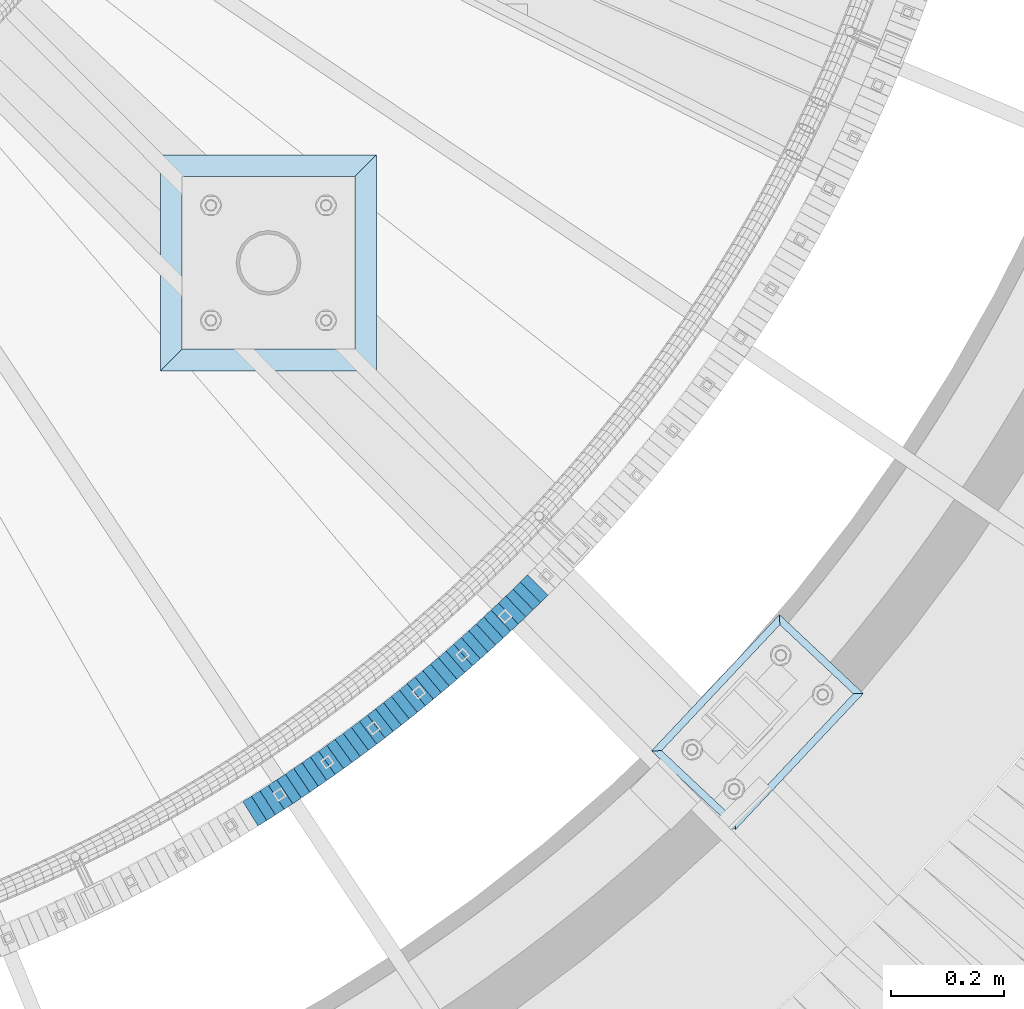
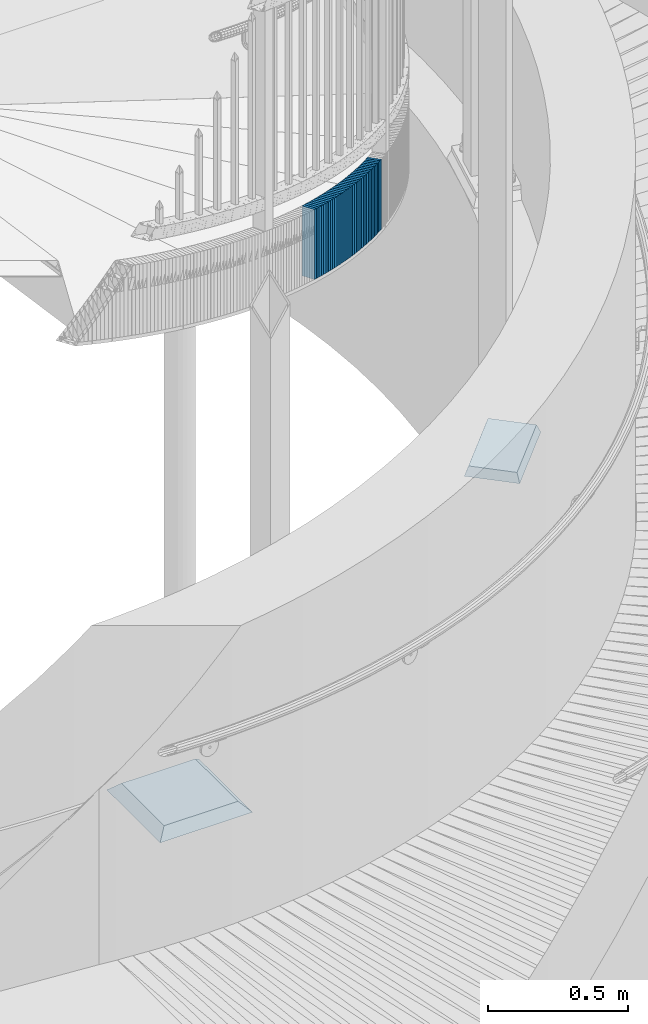
# One storey, part 904 of 975: 38 plates.
"""IFC2X3 building model written with IfcOpenShell, lengths in millimetres."""

import ifcopenshell
import ifcopenshell.guid

model = None  # the IFC model being written
_history = None  # IfcOwnerHistory: only IFC2X3 demands one
_inside = {}  # id of a spatial element -> (the spatial element, [elements in it])
_under = {}  # id of a project, library or spatial element -> (it, [spatial elements below it])
_declared = {}  # id of a project -> (the project, [libraries it declares])
_typed = {}  # id of a type object -> (the type object, [elements of that type])
_made_of = {}  # id of a material, layer set ... -> (it, [elements and type objects made of it])


def new_model(schema):
    """Start an empty IFC model of exactly this schema.

    Asked for "IFC4X3", IfcOpenShell would pick the latest addendum, in which some entities
    have other attributes; the version numbers below select the first issue.
    IFC2X3 requires an IfcOwnerHistory on every rooted entity: one is made here for all.
    """
    global model, _history
    if schema == "IFC4X3":
        model = ifcopenshell.file(schema_version=(4, 3, 0, 0))
    else:
        model = ifcopenshell.file(schema=schema)
    _inside.clear()
    _under.clear()
    _declared.clear()
    _typed.clear()
    _made_of.clear()
    _history = None
    if model.schema == "IFC2X3":
        org = make("IfcOrganization", Name="unknown")
        user = make(
            "IfcPersonAndOrganization",
            ThePerson=make("IfcPerson", FamilyName="unknown"),
            TheOrganization=org,
        )
        app = make(
            "IfcApplication",
            ApplicationDeveloper=org,
            Version="unknown",
            ApplicationFullName="unknown",
            ApplicationIdentifier="unknown",
        )
        _history = make(
            "IfcOwnerHistory",
            OwningUser=user,
            OwningApplication=app,
            ChangeAction="ADDED",
            CreationDate=0,
        )
    return model


def make(cls, **values):
    """One entity of the class cls with the attributes given. An attribute that is None is left unset."""
    return model.create_entity(
        cls, **{name: value for name, value in values.items() if value is not None}
    )


def rooted(cls, **values):
    """An entity with a GlobalId (a new one), such as an element, a storey or a relation."""
    return make(cls, GlobalId=ifcopenshell.guid.new(), OwnerHistory=_history, **values)


def si_unit(unit_type, name, prefix=None):
    """IfcSIUnit, for example si_unit("LENGTHUNIT", "METRE", prefix="MILLI")."""
    return make("IfcSIUnit", UnitType=unit_type, Prefix=prefix, Name=name)


def assignment(units):
    """IfcUnitAssignment: the units of a project."""
    return None if units is None else make("IfcUnitAssignment", Units=units)


def point(xyz):
    """IfcCartesianPoint."""
    return None if xyz is None else make("IfcCartesianPoint", Coordinates=xyz)


def direction(xyz):
    """IfcDirection."""
    return None if xyz is None else make("IfcDirection", DirectionRatios=xyz)


def frame(location, z_axis=None, x_axis=None):
    """IfcAxis2Placement3D, a coordinate frame: its origin and axes. An axis left out is left unset."""
    return make(
        "IfcAxis2Placement3D",
        Location=point(location),
        Axis=direction(z_axis),
        RefDirection=direction(x_axis),
    )


def origin_with_axes():
    """The frame at (0, 0, 0) with the z axis (0, 0, 1) and the x axis (1, 0, 0) written out."""
    return frame((0.0, 0.0, 0.0), z_axis=(0.0, 0.0, 1.0), x_axis=(1.0, 0.0, 0.0))


def place(relative_to, where):
    """IfcLocalPlacement: puts the frame where relative to a parent placement (None: the world)."""
    return make(
        "IfcLocalPlacement", PlacementRelTo=relative_to, RelativePlacement=where
    )


def context(
    kind, dimensions, precision=None, world=None, true_north=None, identifier=None
):
    """IfcGeometricRepresentationContext, for example the 3D "Model" context."""
    return make(
        "IfcGeometricRepresentationContext",
        ContextIdentifier=identifier,
        ContextType=kind,
        CoordinateSpaceDimension=dimensions,
        Precision=precision,
        WorldCoordinateSystem=world,
        TrueNorth=true_north,
    )


def subcontext(parent, identifier, kind, view, scale=None):
    """IfcGeometricRepresentationSubContext, for example "Body" below "Model"."""
    return make(
        "IfcGeometricRepresentationSubContext",
        ContextIdentifier=identifier,
        ContextType=kind,
        ParentContext=parent,
        TargetScale=scale,
        TargetView=view,
    )


def project(units=None, contexts=None):
    """IfcProject with its units and contexts."""
    return rooted(
        "IfcProject",
        Name="project",
        RepresentationContexts=contexts,
        UnitsInContext=assignment(units),
    )


def spatial(cls, under=None, at=None, **own):
    """A site, building, storey or space (cls), placed at a placement, below another one or the project."""
    s = rooted(cls, ObjectPlacement=at, **own)
    if under is not None:
        _under.setdefault(under.id(), (under, []))[1].append(s)
    return s


def faces_of(points, faces, orient=None, outer=None):
    """IfcFace entities. A face is a list of loops; a loop is a list of indices into points, from 0.

    orient and outer hold one flag for each loop. By default every Orientation is true, the
    first loop of a face is its IfcFaceOuterBound and the others are IfcFaceBound.
    """
    made = []
    for i, loops in enumerate(faces):
        bounds = []
        for j, loop in enumerate(loops):
            is_outer = j == 0 if outer is None else outer[i][j]
            bounds.append(
                make(
                    "IfcFaceOuterBound" if is_outer else "IfcFaceBound",
                    Bound=make("IfcPolyLoop", Polygon=[points[k] for k in loop]),
                    Orientation=True if orient is None else orient[i][j],
                )
            )
        made.append(make("IfcFace", Bounds=bounds))
    return made


def faceted_brep(points, faces, orient=None, outer=None, voids=None):
    """IfcFacetedBrep: a solid bounded by flat faces; with voids (closed shells), ...WithVoids."""
    shared = [point(p) for p in points]
    hull = make("IfcClosedShell", CfsFaces=faces_of(shared, faces, orient, outer))
    if voids is None:
        return make("IfcFacetedBrep", Outer=hull)
    return make(
        "IfcFacetedBrepWithVoids",
        Outer=hull,
        Voids=[
            make(cls, CfsFaces=faces_of(shared, fs, o, b)) for cls, fs, o, b in voids
        ],
    )


def shape(context_of_items, identifier, shape_type, items):
    """IfcShapeRepresentation: the items that make up one representation, for example the "Body"."""
    return make(
        "IfcShapeRepresentation",
        ContextOfItems=context_of_items,
        RepresentationIdentifier=identifier,
        RepresentationType=shape_type,
        Items=items,
    )


def material(Name=None, Category=None):
    """IfcMaterial."""
    return make("IfcMaterial", Name=Name, Category=Category)


def made_of(thing, what):
    """Note that an element or type object is made of a material, layer set ...; save() writes the relation."""
    if what is not None:
        _made_of.setdefault(what.id(), (what, []))[1].append(thing)
    return thing


def type_object(cls, material=None, **own):
    """A type object (cls), such as IfcWallType, which elements share."""
    return made_of(rooted(cls, **own), material)


def element(
    cls,
    number,
    at=None,
    inside=None,
    cuts=None,
    type_object=None,
    material=None,
    context=None,
    identifier="Body",
    shape_type=None,
    held_by="IfcProductDefinitionShape",
    body=None,
    shapes=None,
    **own,
):
    """One element of the class cls, such as IfcWall. Its Tag is "e" and its number.

    at: its placement. inside: the storey or other place that contains it. cuts: it is an
    opening in that element (IfcRelVoidsElement). A single representation is given by context,
    identifier, shape_type and body (its items); several are given by shapes. held_by: the class
    of the entity that holds the representations. save() writes the other relations.
    """
    e = rooted(cls, Tag="e%d" % number, ObjectPlacement=at, **own)
    if body is not None:
        shapes = [shape(context, identifier, shape_type, body)]
    if shapes is not None:
        e.Representation = make(held_by, Representations=shapes)
    if inside is not None:
        _inside.setdefault(inside.id(), (inside, []))[1].append(e)
    if cuts is not None:
        rooted(
            "IfcRelVoidsElement", RelatingBuildingElement=cuts, RelatedOpeningElement=e
        )
    if type_object is not None:
        _typed.setdefault(type_object.id(), (type_object, []))[1].append(e)
    return made_of(e, material)


def aggregate(whole, parts):
    """IfcRelAggregates: a whole, such as a stair, and the parts it consists of."""
    return rooted("IfcRelAggregates", RelatingObject=whole, RelatedObjects=parts)


def save(model, path):
    """Write the relations noted so far, then the file.

    IfcRelAggregates (storeys below a building ...), IfcRelContainedInSpatialStructure (elements
    in a storey), IfcRelDefinesByType, IfcRelAssociatesMaterial and IfcRelDeclares: one each for
    every whole, place, type object, material and project.
    """
    for whole, parts in _under.values():
        aggregate(whole, parts)
    for where, things in _inside.values():
        rooted(
            "IfcRelContainedInSpatialStructure",
            RelatedElements=things,
            RelatingStructure=where,
        )
    for kind, things in _typed.values():
        rooted("IfcRelDefinesByType", RelatedObjects=things, RelatingType=kind)
    for what, things in _made_of.values():
        rooted("IfcRelAssociatesMaterial", RelatedObjects=things, RelatingMaterial=what)
    for by, libraries in _declared.values():
        rooted("IfcRelDeclares", RelatingContext=by, RelatedDefinitions=libraries)
    model.write(path)


model = new_model("IFC2X3")

# Units and contexts
model_context = context("Model", 3, precision=1e-05, world=origin_with_axes())
body_context = subcontext(model_context, "Body", "Model", "MODEL_VIEW")
ifc_project = project(units=[si_unit("LENGTHUNIT", "METRE", prefix="MILLI"), si_unit("AREAUNIT", "SQUARE_METRE"), si_unit("VOLUMEUNIT", "CUBIC_METRE"), si_unit("MASSUNIT", "GRAM", prefix="KILO"), si_unit("TIMEUNIT", "SECOND"), si_unit("PLANEANGLEUNIT", "RADIAN"), si_unit("SOLIDANGLEUNIT", "STERADIAN"), si_unit("THERMODYNAMICTEMPERATUREUNIT", "DEGREE_CELSIUS"), si_unit("LUMINOUSINTENSITYUNIT", "LUMEN")], contexts=[model_context])

# Site, building, storey
site_placement = place(None, origin_with_axes())
site = spatial("IfcSite", under=ifc_project, at=site_placement, CompositionType="ELEMENT")
building_placement = place(site_placement, origin_with_axes())
building = spatial("IfcBuilding", under=site, at=building_placement, Name="Undefined", CompositionType="ELEMENT")
storey_placement = place(building_placement, origin_with_axes())
storey = spatial("IfcBuildingStorey", under=building, at=storey_placement, Name="Undefined", CompositionType="ELEMENT", Elevation=0.0)

# Plates
ifc_material_1 = material(Name="STEEL/A36")
plate_type_1 = type_object("IfcPlateType", PredefinedType="NOTDEFINED")
plate_1_placement = place(storey_placement, frame((36272.917348315, 979.903172533605, 2546.48750006771), z_axis=(-0.846420002588978, -0.532515895741408, 0.0), x_axis=(0.0, 0.0, 1.0)))
element("IfcPlate", 1, at=plate_1_placement, inside=storey, type_object=plate_type_1, material=ifc_material_1, Name="WALL", context=body_context, shape_type="Brep", body=[
    faceted_brep([(0.0, -25.3999999999724, -1.81898940354586e-11), (5.69999980926514, -25.3999999999651, 17.8440475463649), (5.69999980926514, 25.3999999999942, 17.8440475463904), (0.0, 25.3999999999869, 1.45519152283669e-11), (310.5, -25.3999999999651, 17.8440475463649), (310.5, 25.3999999999942, 17.8440475463904), (304.799987792969, -25.3999999999724, -1.81898940354586e-11), (304.799987792969, 25.3999999999869, 1.45519152283669e-11)], [[[0, 1, 2, 3]], [[1, 4, 5, 2]], [[4, 6, 7, 5]], [[6, 0, 3, 7]], [[5, 7, 3, 2]], [[6, 4, 1, 0]]]),
])
plate_2_placement = place(storey_placement, frame((36288.1188956409, 989.567395668225, 2540.68750006771), z_axis=(-0.843891532718926, -0.536513821821304, 0.0), x_axis=(0.0, 0.0, 1.0)))
element("IfcPlate", 2, at=plate_2_placement, inside=storey, type_object=plate_type_1, material=ifc_material_1, Name="WALL", context=body_context, shape_type="Brep", body=[
    faceted_brep([(0.0, -25.3999999999724, -1.81898940354586e-11), (5.80000019073486, -25.4000000000451, 17.8891029358201), (5.80000019073486, 25.4000000000087, 17.8891029357856), (0.0, 25.3999999999869, 1.45519152283669e-11), (310.600006103516, -25.4000000000451, 17.8891029358201), (310.600006103516, 25.4000000000087, 17.8891029357856), (304.799987792969, -25.3999999999724, -1.81898940354586e-11), (304.799987792969, 25.3999999999869, 1.45519152283669e-11)], [[[0, 1, 2, 3]], [[1, 4, 5, 2]], [[4, 6, 7, 5]], [[6, 0, 3, 7]], [[5, 7, 3, 2]], [[6, 4, 1, 0]]]),
])
plate_3_placement = place(storey_placement, frame((36303.2841307244, 999.373344502733, 2534.98750006771), z_axis=(-0.83972031877, -0.543019139851267, 0.0), x_axis=(0.0, 0.0, 1.0)))
element("IfcPlate", 3, at=plate_3_placement, inside=storey, type_object=plate_type_1, material=ifc_material_1, Name="WALL", context=body_context, shape_type="Brep", body=[
    faceted_brep([(0.0, -25.3999999999724, -1.81898940354586e-11), (5.69999980926514, -25.4000000000378, 17.8639297485788), (5.69999980926514, 25.3999999999833, 17.8639297485533), (0.0, 25.3999999999869, 1.45519152283669e-11), (310.5, -25.4000000000378, 17.8639297485788), (310.5, 25.3999999999833, 17.8639297485533), (304.799987792969, -25.3999999999724, -1.81898940354586e-11), (304.799987792969, 25.3999999999869, 1.45519152283669e-11)], [[[0, 1, 2, 3]], [[1, 4, 5, 2]], [[4, 6, 7, 5]], [[6, 0, 3, 7]], [[5, 7, 3, 2]], [[6, 4, 1, 0]]]),
])
plate_4_placement = place(storey_placement, frame((36318.3490877869, 1009.28092593627, 2529.28750006771), z_axis=(-0.835484829267466, -0.549513512175918, 0.0), x_axis=(0.0, 0.0, 1.0)))
element("IfcPlate", 4, at=plate_4_placement, inside=storey, type_object=plate_type_1, material=ifc_material_1, Name="WALL", context=body_context, shape_type="Brep", body=[
    faceted_brep([(0.0, -25.3999999999724, -1.81898940354586e-11), (5.69999980926514, -25.3999999999724, 17.833955764745), (5.69999980926514, 25.3999999999905, 17.8339557647923), (0.0, 25.3999999999869, 1.45519152283669e-11), (310.5, -25.3999999999724, 17.833955764745), (310.5, 25.3999999999905, 17.8339557647923), (304.799987792969, -25.3999999999724, -1.81898940354586e-11), (304.799987792969, 25.3999999999869, 1.45519152283669e-11)], [[[0, 1, 2, 3]], [[1, 4, 5, 2]], [[4, 6, 7, 5]], [[6, 0, 3, 7]], [[5, 7, 3, 2]], [[6, 4, 1, 0]]]),
])
plate_5_placement = place(storey_placement, frame((36333.3480466602, 1019.24634454331, 2523.48750006771), z_axis=(-0.832909293569711, -0.553409530714104, 0.0), x_axis=(0.0, 0.0, 1.0)))
element("IfcPlate", 5, at=plate_5_placement, inside=storey, type_object=plate_type_1, material=ifc_material_1, Name="WALL", context=body_context, shape_type="Brep", body=[
    faceted_brep([(0.0, -25.3999999999724, -1.81898940354586e-11), (5.80000019073486, -25.4000000000451, 17.8891029358201), (5.80000019073486, 25.4000000000087, 17.8891029357856), (0.0, 25.3999999999869, 1.45519152283669e-11), (310.600006103516, -25.4000000000451, 17.8891029358201), (310.600006103516, 25.4000000000087, 17.8891029357856), (304.799987792969, -25.3999999999724, -1.81898940354586e-11), (304.799987792969, 25.3999999999869, 1.45519152283669e-11)], [[[0, 1, 2, 3]], [[1, 4, 5, 2]], [[4, 6, 7, 5]], [[6, 0, 3, 7]], [[5, 7, 3, 2]], [[6, 4, 1, 0]]]),
])
plate_6_placement = place(storey_placement, frame((36348.3118228137, 1029.35608078971, 2517.78750006771), z_axis=(-0.828588968917096, -0.559857410943987, 0.0), x_axis=(0.0, 0.0, 1.0)))
element("IfcPlate", 6, at=plate_6_placement, inside=storey, type_object=plate_type_1, material=ifc_material_1, Name="WALL", context=body_context, shape_type="Brep", body=[
    faceted_brep([(0.0, -25.3999999999724, -1.81898940354586e-11), (5.69999980926514, -25.4000000000378, 17.8639297485788), (5.69999980926514, 25.3999999999833, 17.8639297485533), (0.0, 25.3999999999869, 1.45519152283669e-11), (310.5, -25.4000000000378, 17.8639297485788), (310.5, 25.3999999999833, 17.8639297485533), (304.799987792969, -25.3999999999724, -1.81898940354586e-11), (304.799987792969, 25.3999999999869, 1.45519152283669e-11)], [[[0, 1, 2, 3]], [[1, 4, 5, 2]], [[4, 6, 7, 5]], [[6, 0, 3, 7]], [[5, 7, 3, 2]], [[6, 4, 1, 0]]]),
])
plate_7_placement = place(storey_placement, frame((36363.1752319909, 1039.5674212849, 2512.08750006771), z_axis=(-0.824205484847631, -0.566290842895311, 0.0), x_axis=(0.0, 0.0, 1.0)))
element("IfcPlate", 7, at=plate_7_placement, inside=storey, type_object=plate_type_1, material=ifc_material_1, Name="WALL", context=body_context, shape_type="Brep", body=[
    faceted_brep([(0.0, -25.3999999999724, -1.81898940354586e-11), (5.69999980926514, -25.3999999999651, 17.8440475463649), (5.69999980926514, 25.3999999999942, 17.8440475463904), (0.0, 25.3999999999869, 1.45519152283669e-11), (310.5, -25.3999999999651, 17.8440475463649), (310.5, 25.3999999999942, 17.8440475463904), (304.799987792969, -25.3999999999724, -1.81898940354586e-11), (304.799987792969, 25.3999999999869, 1.45519152283669e-11)], [[[0, 1, 2, 3]], [[1, 4, 5, 2]], [[4, 6, 7, 5]], [[6, 0, 3, 7]], [[5, 7, 3, 2]], [[6, 4, 1, 0]]]),
])
plate_8_placement = place(storey_placement, frame((36377.9715158971, 1049.83390250907, 2506.38750006771), z_axis=(-0.821588113820829, -0.570081547875681, 0.0), x_axis=(0.0, 0.0, 1.0)))
element("IfcPlate", 8, at=plate_8_placement, inside=storey, type_object=plate_type_1, material=ifc_material_1, Name="WALL", context=body_context, shape_type="Brep", body=[
    faceted_brep([(0.0, -25.3999999999724, -1.81898940354586e-11), (5.69999980926514, -25.3999999999614, 17.8921775817616), (5.69999980926514, 25.400000000016, 17.8921775817726), (0.0, 25.3999999999869, 1.45519152283669e-11), (310.5, -25.3999999999614, 17.8921775817616), (310.5, 25.400000000016, 17.8921775817726), (304.799987792969, -25.3999999999724, -1.81898940354586e-11), (304.799987792969, 25.3999999999869, 1.45519152283669e-11)], [[[0, 1, 2, 3]], [[1, 4, 5, 2]], [[4, 6, 7, 5]], [[6, 0, 3, 7]], [[5, 7, 3, 2]], [[6, 4, 1, 0]]]),
])
plate_9_placement = place(storey_placement, frame((36392.7336160576, 1060.24731794665, 2500.58750006771), z_axis=(-0.817122939119161, -0.576463444084067, 0.0), x_axis=(0.0, 0.0, 1.0)))
element("IfcPlate", 9, at=plate_9_placement, inside=storey, type_object=plate_type_1, material=ifc_material_1, Name="WALL", context=body_context, shape_type="Brep", body=[
    faceted_brep([(0.0, -25.3999999999724, -1.81898940354586e-11), (5.80000019073486, -25.3999999999705, 17.873443603421), (5.80000019073486, 25.3999999999924, 17.8734436035338), (0.0, 25.3999999999869, 1.45519152283669e-11), (310.600006103516, -25.3999999999705, 17.873443603421), (310.600006103516, 25.3999999999924, 17.8734436035338), (304.799987792969, -25.3999999999724, -1.81898940354586e-11), (304.799987792969, 25.3999999999869, 1.45519152283669e-11)], [[[0, 1, 2, 3]], [[1, 4, 5, 2]], [[4, 6, 7, 5]], [[6, 0, 3, 7]], [[5, 7, 3, 2]], [[6, 4, 1, 0]]]),
])
plate_10_placement = place(storey_placement, frame((36407.3008082766, 1070.59488394597, 2494.88750006771), z_axis=(-0.815250261985312, -0.579108806989567, 0.0), x_axis=(0.0, 0.0, 1.0)))
element("IfcPlate", 10, at=plate_10_placement, inside=storey, type_object=plate_type_1, material=ifc_material_1, Name="WALL", context=body_context, shape_type="Brep", body=[
    faceted_brep([(0.0, -25.3999999999724, -1.81898940354586e-11), (5.69999980926514, -25.4000000000251, 17.7924137116061), (5.69999980926514, 25.4000000000051, 17.7924137115479), (0.0, 25.3999999999869, 1.45519152283669e-11), (310.5, -25.4000000000251, 17.7924137116061), (310.5, 25.4000000000051, 17.7924137115479), (304.799987792969, -25.3999999999724, -1.81898940354586e-11), (304.799987792969, 25.3999999999869, 1.45519152283669e-11)], [[[0, 1, 2, 3]], [[1, 4, 5, 2]], [[4, 6, 7, 5]], [[6, 0, 3, 7]], [[5, 7, 3, 2]], [[6, 4, 1, 0]]]),
])
plate_11_placement = place(storey_placement, frame((36421.9887938069, 1081.22971070742, 2489.18750006771), z_axis=(-0.80994212177235, -0.58650981183515, 0.0), x_axis=(0.0, 0.0, 1.0)))
element("IfcPlate", 11, at=plate_11_placement, inside=storey, type_object=plate_type_1, material=ifc_material_1, Name="WALL", context=body_context, shape_type="Brep", body=[
    faceted_brep([(0.0, -25.3999999999724, -1.81898940354586e-11), (5.69999980926514, -25.3999999999978, 17.9011173248218), (5.69999980926514, 25.4000000000087, 17.9011173248182), (0.0, 25.3999999999869, 1.45519152283669e-11), (310.5, -25.3999999999978, 17.9011173248218), (310.5, 25.4000000000087, 17.9011173248182), (304.799987792969, -25.3999999999724, -1.81898940354586e-11), (304.799987792969, 25.3999999999869, 1.45519152283669e-11)], [[[0, 1, 2, 3]], [[1, 4, 5, 2]], [[4, 6, 7, 5]], [[6, 0, 3, 7]], [[5, 7, 3, 2]], [[6, 4, 1, 0]]]),
])
plate_12_placement = place(storey_placement, frame((36436.4564173815, 1091.77884932939, 2483.48750006771), z_axis=(-0.808007530355228, -0.589172157259018, 0.0), x_axis=(0.0, 0.0, 1.0)))
element("IfcPlate", 12, at=plate_12_placement, inside=storey, type_object=plate_type_1, material=ifc_material_1, Name="WALL", context=body_context, shape_type="Brep", body=[
    faceted_brep([(0.0, -25.3999999999724, -1.81898940354586e-11), (5.69999980926514, -25.3999999999432, 17.8213348388126), (5.69999980926514, 25.3999999999905, 17.8213348388708), (0.0, 25.3999999999869, 1.45519152283669e-11), (310.5, -25.3999999999432, 17.8213348388126), (310.5, 25.3999999999905, 17.8213348388708), (304.799987792969, -25.3999999999724, -1.81898940354586e-11), (304.799987792969, 25.3999999999869, 1.45519152283669e-11)], [[[0, 1, 2, 3]], [[1, 4, 5, 2]], [[4, 6, 7, 5]], [[6, 0, 3, 7]], [[5, 7, 3, 2]], [[6, 4, 1, 0]]]),
])
plate_13_placement = place(storey_placement, frame((36451.0406808038, 1102.61448344115, 2477.68750006771), z_axis=(-0.802667604703166, -0.596426622779435, 0.0), x_axis=(0.0, 0.0, 1.0)))
element("IfcPlate", 13, at=plate_13_placement, inside=storey, type_object=plate_type_1, material=ifc_material_1, Name="WALL", context=body_context, shape_type="Brep", body=[
    faceted_brep([(0.0, -25.3999999999724, -1.81898940354586e-11), (5.80000019073486, -25.3999999999614, 17.9424076079595), (5.80000019073486, 25.3999999999978, 17.9424076080322), (0.0, 25.3999999999869, 1.45519152283669e-11), (310.600006103516, -25.3999999999614, 17.9424076079595), (310.600006103516, 25.3999999999978, 17.9424076080322), (304.799987792969, -25.3999999999724, -1.81898940354586e-11), (304.799987792969, 25.3999999999869, 1.45519152283669e-11)], [[[0, 1, 2, 3]], [[1, 4, 5, 2]], [[4, 6, 7, 5]], [[6, 0, 3, 7]], [[5, 7, 3, 2]], [[6, 4, 1, 0]]]),
])
plate_14_placement = place(storey_placement, frame((36465.408680298, 1113.36518729053, 2471.98750006771), z_axis=(-0.800671390161604, -0.59910376812092, 0.0), x_axis=(0.0, 0.0, 1.0)))
element("IfcPlate", 14, at=plate_14_placement, inside=storey, type_object=plate_type_1, material=ifc_material_1, Name="WALL", context=body_context, shape_type="Brep", body=[
    faceted_brep([(0.0, -25.3999999999724, -1.81898940354586e-11), (5.69999980926514, -25.4000000000378, 17.8639297485788), (5.69999980926514, 25.3999999999833, 17.8639297485533), (0.0, 25.3999999999869, 1.45519152283669e-11), (310.5, -25.4000000000378, 17.8639297485788), (310.5, 25.3999999999833, 17.8639297485533), (304.799987792969, -25.3999999999724, -1.81898940354586e-11), (304.799987792969, 25.3999999999869, 1.45519152283669e-11)], [[[0, 1, 2, 3]], [[1, 4, 5, 2]], [[4, 6, 7, 5]], [[6, 0, 3, 7]], [[5, 7, 3, 2]], [[6, 4, 1, 0]]]),
])
plate_15_placement = place(storey_placement, frame((36479.7677783555, 1124.28520917077, 2466.28750006771), z_axis=(-0.795946119280133, -0.605367471213061, 0.0), x_axis=(0.0, 0.0, 1.0)))
element("IfcPlate", 15, at=plate_15_placement, inside=storey, type_object=plate_type_1, material=ifc_material_1, Name="WALL", context=body_context, shape_type="Brep", body=[
    faceted_brep([(0.0, -25.3999999999724, -1.81898940354586e-11), (5.69999980926514, -25.3999999999651, 17.8440475463649), (5.69999980926514, 25.3999999999942, 17.8440475463904), (0.0, 25.3999999999869, 1.45519152283669e-11), (310.5, -25.3999999999651, 17.8440475463649), (310.5, 25.3999999999942, 17.8440475463904), (304.799987792969, -25.3999999999724, -1.81898940354586e-11), (304.799987792969, 25.3999999999869, 1.45519152283669e-11)], [[[0, 1, 2, 3]], [[1, 4, 5, 2]], [[4, 6, 7, 5]], [[6, 0, 3, 7]], [[5, 7, 3, 2]], [[6, 4, 1, 0]]]),
])
plate_16_placement = place(storey_placement, frame((36494.1150183444, 1135.47565969161, 2460.48750006771), z_axis=(-0.788448067278478, -0.615101329217254, 0.0), x_axis=(0.0, 0.0, 1.0)))
element("IfcPlate", 16, at=plate_16_placement, inside=storey, type_object=plate_type_1, material=ifc_material_1, Name="WALL", context=body_context, shape_type="Brep", body=[
    faceted_brep([(0.0, -25.3999999999724, -1.81898940354586e-11), (5.80000019073486, -25.3999999999978, 17.8832321166956), (5.80000019073486, 25.4000000000415, 17.8832321166556), (0.0, 25.3999999999869, 1.45519152283669e-11), (310.600006103516, -25.3999999999978, 17.8832321166956), (310.600006103516, 25.4000000000415, 17.8832321166556), (304.799987792969, -25.3999999999724, -1.81898940354586e-11), (304.799987792969, 25.3999999999869, 1.45519152283669e-11)], [[[0, 1, 2, 3]], [[1, 4, 5, 2]], [[4, 6, 7, 5]], [[6, 0, 3, 7]], [[5, 7, 3, 2]], [[6, 4, 1, 0]]]),
])
plate_17_placement = place(storey_placement, frame((36508.2150183401, 1146.47565969129, 2454.78750006771), z_axis=(-0.788448067278478, -0.615101329217254, 0.0), x_axis=(0.0, 0.0, 1.0)))
element("IfcPlate", 17, at=plate_17_placement, inside=storey, type_object=plate_type_1, material=ifc_material_1, Name="WALL", context=body_context, shape_type="Brep", body=[
    faceted_brep([(0.0, -25.3999999999724, -1.81898940354586e-11), (5.69999980926514, -25.3999999999687, 17.8807163238307), (5.69999980926514, 25.400000000016, 17.880716323838), (0.0, 25.3999999999869, 1.45519152283669e-11), (310.5, -25.3999999999687, 17.8807163238307), (310.5, 25.400000000016, 17.880716323838), (304.799987792969, -25.3999999999724, -1.81898940354586e-11), (304.799987792969, 25.3999999999869, 1.45519152283669e-11)], [[[0, 1, 2, 3]], [[1, 4, 5, 2]], [[4, 6, 7, 5]], [[6, 0, 3, 7]], [[5, 7, 3, 2]], [[6, 4, 1, 0]]]),
])
plate_18_placement = place(storey_placement, frame((36522.3718606982, 1157.69901304339, 2449.08750006771), z_axis=(-0.783591636094263, -0.621276225074737, 0.0), x_axis=(0.0, 0.0, 1.0)))
element("IfcPlate", 18, at=plate_18_placement, inside=storey, type_object=plate_type_1, material=ifc_material_1, Name="WALL", context=body_context, shape_type="Brep", body=[
    faceted_brep([(0.0, -25.3999999999724, -1.81898940354586e-11), (5.69999980926514, -25.3999999999469, 17.8731651305425), (5.69999980926514, 25.3999999999869, 17.8731651306334), (0.0, 25.3999999999869, 1.45519152283669e-11), (310.5, -25.3999999999469, 17.8731651305425), (310.5, 25.3999999999869, 17.8731651306334), (304.799987792969, -25.3999999999724, -1.81898940354586e-11), (304.799987792969, 25.3999999999869, 1.45519152283669e-11)], [[[0, 1, 2, 3]], [[1, 4, 5, 2]], [[4, 6, 7, 5]], [[6, 0, 3, 7]], [[5, 7, 3, 2]], [[6, 4, 1, 0]]]),
])
plate_19_placement = place(storey_placement, frame((36536.4586987988, 1168.96817285019, 2443.28750006771), z_axis=(-0.780868809052786, -0.624695048042229, 0.0), x_axis=(0.0, 0.0, 1.0)))
element("IfcPlate", 19, at=plate_19_placement, inside=storey, type_object=plate_type_1, material=ifc_material_1, Name="WALL", context=body_context, shape_type="Brep", body=[
    faceted_brep([(0.0, -25.3999999999724, -1.81898940354586e-11), (5.80000019073486, -25.3999999999833, 17.9287471770986), (5.80000019073486, 25.4000000000087, 17.9287471771167), (0.0, 25.3999999999869, 1.45519152283669e-11), (310.600006103516, -25.3999999999833, 17.9287471770986), (310.600006103516, 25.4000000000087, 17.9287471771167), (304.799987792969, -25.3999999999724, -1.81898940354586e-11), (304.799987792969, 25.3999999999869, 1.45519152283669e-11)], [[[0, 1, 2, 3]], [[1, 4, 5, 2]], [[4, 6, 7, 5]], [[6, 0, 3, 7]], [[5, 7, 3, 2]], [[6, 4, 1, 0]]]),
])
plate_20_placement = place(storey_placement, frame((36550.4834380396, 1180.45007160302, 2437.58750006771), z_axis=(-0.773707440821245, -0.633543049853631, 0.0), x_axis=(0.0, 0.0, 1.0)))
element("IfcPlate", 20, at=plate_20_placement, inside=storey, type_object=plate_type_1, material=ifc_material_1, Name="WALL", context=body_context, shape_type="Brep", body=[
    faceted_brep([(0.0, -25.3999999999724, -1.81898940354586e-11), (5.69999980926514, -25.3999999999651, 17.8440475463649), (5.69999980926514, 25.3999999999942, 17.8440475463904), (0.0, 25.3999999999869, 1.45519152283669e-11), (310.5, -25.3999999999651, 17.8440475463649), (310.5, 25.3999999999942, 17.8440475463904), (304.799987792969, -25.3999999999724, -1.81898940354586e-11), (304.799987792969, 25.3999999999869, 1.45519152283669e-11)], [[[0, 1, 2, 3]], [[1, 4, 5, 2]], [[4, 6, 7, 5]], [[6, 0, 3, 7]], [[5, 7, 3, 2]], [[6, 4, 1, 0]]]),
])
plate_21_placement = place(storey_placement, frame((36564.3987557469, 1191.86262434497, 2431.78750006771), z_axis=(-0.773213238395001, -0.63414610932396, 0.0), x_axis=(0.0, 0.0, 1.0)))
element("IfcPlate", 21, at=plate_21_placement, inside=storey, type_object=plate_type_1, material=ifc_material_1, Name="WALL", context=body_context, shape_type="Brep", body=[
    faceted_brep([(0.0, -25.3999999999724, -1.81898940354586e-11), (5.80000019073486, -25.3999999999505, 17.9788761138298), (5.80000019073486, 25.4000000000196, 17.9788761138625), (0.0, 25.3999999999869, 1.45519152283669e-11), (310.600006103516, -25.3999999999505, 17.9788761138298), (310.600006103516, 25.4000000000196, 17.9788761138625), (304.799987792969, -25.3999999999724, -1.81898940354586e-11), (304.799987792969, 25.3999999999869, 1.45519152283669e-11)], [[[0, 1, 2, 3]], [[1, 4, 5, 2]], [[4, 6, 7, 5]], [[6, 0, 3, 7]], [[5, 7, 3, 2]], [[6, 4, 1, 0]]]),
])
for number, where, z_axis, x_axis, name in (
    (22, (36578.3218620237, 1203.54774328668, 2426.08750006771), (-0.765925091094034, -0.642929821078939, 0.0), (0.0, 0.0, 1.0), "WALL"),
    (23, (36592.021862022, 1215.04774328654, 2420.38750006771), (-0.765925091094034, -0.642929821078939, 0.0), (0.0, 0.0, 1.0), "WALL"),
):
    element("IfcPlate", number, at=place(storey_placement, frame(where, z_axis=z_axis, x_axis=x_axis)), inside=storey, type_object=plate_type_1, material=ifc_material_1, Name=name, context=body_context, shape_type="Brep", body=[
        faceted_brep([(0.0, -25.3999999999724, -1.81898940354586e-11), (5.69999980926514, -25.3999999999614, 17.8921775817616), (5.69999980926514, 25.400000000016, 17.8921775817726), (0.0, 25.3999999999869, 1.45519152283669e-11), (310.5, -25.3999999999614, 17.8921775817616), (310.5, 25.400000000016, 17.8921775817726), (304.799987792969, -25.3999999999724, -1.81898940354586e-11), (304.799987792969, 25.3999999999869, 1.45519152283669e-11)], [[[0, 1, 2, 3]], [[1, 4, 5, 2]], [[4, 6, 7, 5]], [[6, 0, 3, 7]], [[5, 7, 3, 2]], [[6, 4, 1, 0]]]),
    ])
for number, where, z_axis, x_axis, name in (
    (24, (36605.8564972629, 1226.9471366204, 2414.58750006771), (-0.758074959837971, -0.65216742886061, 0.0), (0.0, 0.0, 1.0), "WALL"),
    (25, (36619.4564972661, 1238.64713662038, 2408.78750006771), (-0.758074959837971, -0.65216742886061, 0.0), (0.0, 0.0, 1.0), "WALL"),
):
    element("IfcPlate", number, at=place(storey_placement, frame(where, z_axis=z_axis, x_axis=x_axis)), inside=storey, type_object=plate_type_1, material=ifc_material_1, Name=name, context=body_context, shape_type="Brep", body=[
        faceted_brep([(0.0, -25.3999999999724, -1.81898940354586e-11), (5.80000019073486, -25.3999999999614, 17.9424076079595), (5.80000019073486, 25.3999999999978, 17.9424076080322), (0.0, 25.3999999999869, 1.45519152283669e-11), (310.600006103516, -25.3999999999614, 17.9424076079595), (310.600006103516, 25.3999999999978, 17.9424076080322), (304.799987792969, -25.3999999999724, -1.81898940354586e-11), (304.799987792969, 25.3999999999869, 1.45519152283669e-11)], [[[0, 1, 2, 3]], [[1, 4, 5, 2]], [[4, 6, 7, 5]], [[6, 0, 3, 7]], [[5, 7, 3, 2]], [[6, 4, 1, 0]]]),
    ])
plate_22_placement = place(storey_placement, frame((36633.1074302296, 1250.57801973428, 2403.08750006771), z_axis=(-0.752922081330871, -0.658109671289208, 0.0), x_axis=(0.0, 0.0, 1.0)))
element("IfcPlate", 26, at=plate_22_placement, inside=storey, type_object=plate_type_1, material=ifc_material_1, Name="WALL", context=body_context, shape_type="Brep", body=[
    faceted_brep([(0.0, -25.3999999999724, -1.81898940354586e-11), (5.69999980926514, -25.3999999999896, 17.9334888457815), (5.69999980926514, 25.3999999999869, 17.9334888458907), (0.0, 25.3999999999869, 1.45519152283669e-11), (310.5, -25.3999999999896, 17.9334888457815), (310.5, 25.3999999999869, 17.9334888458907), (304.799987792969, -25.3999999999724, -1.81898940354586e-11), (304.799987792969, 25.3999999999869, 1.45519152283669e-11)], [[[0, 1, 2, 3]], [[1, 4, 5, 2]], [[4, 6, 7, 5]], [[6, 0, 3, 7]], [[5, 7, 3, 2]], [[6, 4, 1, 0]]]),
])
plate_23_placement = place(storey_placement, frame((36646.6574871545, 1262.61022628076, 2397.38750006771), z_axis=(-0.747717099182229, -0.664017424161831, 0.0), x_axis=(0.0, 0.0, 1.0)))
element("IfcPlate", 27, at=plate_23_placement, inside=storey, type_object=plate_type_1, material=ifc_material_1, Name="WALL", context=body_context, shape_type="Brep", body=[
    faceted_brep([(0.0, -25.3999999999724, -1.81898940354586e-11), (5.69999980926514, -25.3999999999724, 17.9212169646999), (5.69999980926514, 25.3999999999651, 17.9212169647544), (0.0, 25.3999999999869, 1.45519152283669e-11), (310.5, -25.3999999999724, 17.9212169646999), (310.5, 25.3999999999651, 17.9212169647544), (304.799987792969, -25.3999999999724, -1.81898940354586e-11), (304.799987792969, 25.3999999999869, 1.45519152283669e-11)], [[[0, 1, 2, 3]], [[1, 4, 5, 2]], [[4, 6, 7, 5]], [[6, 0, 3, 7]], [[5, 7, 3, 2]], [[6, 4, 1, 0]]]),
])
plate_24_placement = place(storey_placement, frame((36660.028033994, 1274.57311122478, 2391.58750006771), z_axis=(-0.745241313969715, -0.666794858972902, 0.0), x_axis=(0.0, 0.0, 1.0)))
element("IfcPlate", 28, at=plate_24_placement, inside=storey, type_object=plate_type_1, material=ifc_material_1, Name="WALL", context=body_context, shape_type="Brep", body=[
    faceted_brep([(0.0, -25.3999999999724, -1.81898940354586e-11), (5.80000019073486, -25.4000000000306, 17.853010177645), (5.80000019073486, 25.3999999999578, 17.8530101776596), (0.0, 25.3999999999869, 1.45519152283669e-11), (310.600006103516, -25.4000000000306, 17.853010177645), (310.600006103516, 25.3999999999578, 17.8530101776596), (304.799987792969, -25.3999999999724, -1.81898940354586e-11), (304.799987792969, 25.3999999999869, 1.45519152283669e-11)], [[[0, 1, 2, 3]], [[1, 4, 5, 2]], [[4, 6, 7, 5]], [[6, 0, 3, 7]], [[5, 7, 3, 2]], [[6, 4, 1, 0]]]),
])
plate_25_placement = place(storey_placement, frame((36673.4066372359, 1286.64373539249, 2385.88750006771), z_axis=(-0.742460834916594, -0.669889474924748, 0.0), x_axis=(0.0, 0.0, 1.0)))
element("IfcPlate", 29, at=plate_25_placement, inside=storey, type_object=plate_type_1, material=ifc_material_1, Name="WALL", context=body_context, shape_type="Brep", body=[
    faceted_brep([(0.0, -25.3999999999724, -1.81898940354586e-11), (5.69999980926514, -25.4000000000633, 17.9075393677485), (5.69999980926514, 25.3999999999905, 17.9075393676903), (0.0, 25.3999999999869, 1.45519152283669e-11), (310.5, -25.4000000000633, 17.9075393677485), (310.5, 25.3999999999905, 17.9075393676903), (304.799987792969, -25.3999999999724, -1.81898940354586e-11), (304.799987792969, 25.3999999999869, 1.45519152283669e-11)], [[[0, 1, 2, 3]], [[1, 4, 5, 2]], [[4, 6, 7, 5]], [[6, 0, 3, 7]], [[5, 7, 3, 2]], [[6, 4, 1, 0]]]),
])
plate_26_placement = place(storey_placement, frame((36686.802095926, 1299.11457399584, 2380.08750006771), z_axis=(-0.731797897769698, -0.681521706785522, 0.0), x_axis=(0.0, 0.0, 1.0)))
element("IfcPlate", 30, at=plate_26_placement, inside=storey, type_object=plate_type_1, material=ifc_material_1, Name="WALL", context=body_context, shape_type="Brep", body=[
    faceted_brep([(0.0, -25.3999999999724, -1.81898940354586e-11), (5.80000019073486, -25.399999999936, 17.9011173247382), (5.80000019073486, 25.3999999999578, 17.9011173248837), (0.0, 25.3999999999869, 1.45519152283669e-11), (310.600006103516, -25.399999999936, 17.9011173247382), (310.600006103516, 25.3999999999578, 17.9011173248837), (304.799987792969, -25.3999999999724, -1.81898940354586e-11), (304.799987792969, 25.3999999999869, 1.45519152283669e-11)], [[[0, 1, 2, 3]], [[1, 4, 5, 2]], [[4, 6, 7, 5]], [[6, 0, 3, 7]], [[5, 7, 3, 2]], [[6, 4, 1, 0]]]),
])
plate_27_placement = place(storey_placement, frame((36699.8256740149, 1311.14369468233, 2374.38750006771), z_axis=(-0.734588421928499, -0.678512969933956, 0.0), x_axis=(0.0, 0.0, 1.0)))
element("IfcPlate", 31, at=plate_27_placement, inside=storey, type_object=plate_type_1, material=ifc_material_1, Name="WALL", context=body_context, shape_type="Brep", body=[
    faceted_brep([(0.0, -25.3999999999724, -1.81898940354586e-11), (5.69999980926514, -25.3999999999724, 17.833955764745), (5.69999980926514, 25.3999999999905, 17.8339557647923), (0.0, 25.3999999999869, 1.45519152283669e-11), (310.5, -25.3999999999724, 17.833955764745), (310.5, 25.3999999999905, 17.8339557647923), (304.799987792969, -25.3999999999724, -1.81898940354586e-11), (304.799987792969, 25.3999999999869, 1.45519152283669e-11)], [[[0, 1, 2, 3]], [[1, 4, 5, 2]], [[4, 6, 7, 5]], [[6, 0, 3, 7]], [[5, 7, 3, 2]], [[6, 4, 1, 0]]]),
])
plate_28_placement = place(storey_placement, frame((36713.0483451566, 1323.65185788515, 2368.68750006771), z_axis=(-0.726393020235017, -0.68727955022236, 0.0), x_axis=(0.0, 0.0, 1.0)))
element("IfcPlate", 32, at=plate_28_placement, inside=storey, type_object=plate_type_1, material=ifc_material_1, Name="WALL", context=body_context, shape_type="Brep", body=[
    faceted_brep([(0.0, -25.3999999999724, -1.81898940354586e-11), (5.69999980926514, -25.3999999999978, 17.9011173248218), (5.69999980926514, 25.4000000000087, 17.9011173248182), (0.0, 25.3999999999869, 1.45519152283669e-11), (310.5, -25.3999999999978, 17.9011173248218), (310.5, 25.4000000000087, 17.9011173248182), (304.799987792969, -25.3999999999724, -1.81898940354586e-11), (304.799987792969, 25.3999999999869, 1.45519152283669e-11)], [[[0, 1, 2, 3]], [[1, 4, 5, 2]], [[4, 6, 7, 5]], [[6, 0, 3, 7]], [[5, 7, 3, 2]], [[6, 4, 1, 0]]]),
])
plate_29_placement = place(storey_placement, frame((36726.1228021783, 1336.12259150568, 2362.88750006771), z_axis=(-0.723608232025611, -0.690210929024432, 0.0), x_axis=(0.0, 0.0, 1.0)))
element("IfcPlate", 33, at=plate_29_placement, inside=storey, type_object=plate_type_1, material=ifc_material_1, Name="WALL", context=body_context, shape_type="Brep", body=[
    faceted_brep([(0.0, -25.3999999999724, -1.81898940354586e-11), (5.80000019073486, -25.400000000016, 17.9655227660878), (5.80000019073486, 25.3999999999651, 17.9655227660805), (0.0, 25.3999999999869, 1.45519152283669e-11), (310.600006103516, -25.400000000016, 17.9655227660878), (310.600006103516, 25.3999999999651, 17.9655227660805), (304.799987792969, -25.3999999999724, -1.81898940354586e-11), (304.799987792969, 25.3999999999869, 1.45519152283669e-11)], [[[0, 1, 2, 3]], [[1, 4, 5, 2]], [[4, 6, 7, 5]], [[6, 0, 3, 7]], [[5, 7, 3, 2]], [[6, 4, 1, 0]]]),
])
plate_30_placement = place(storey_placement, frame((36739.0646430586, 1348.65893893989, 2357.18750006771), z_axis=(-0.718240222804792, -0.695795215810889, 0.0), x_axis=(0.0, 0.0, 1.0)))
element("IfcPlate", 34, at=plate_30_placement, inside=storey, type_object=plate_type_1, material=ifc_material_1, Name="WALL", context=body_context, shape_type="Brep", body=[
    faceted_brep([(0.0, -25.3999999999724, -1.81898940354586e-11), (5.69999980926514, -25.3999999999432, 17.8213348388126), (5.69999980926514, 25.3999999999905, 17.8213348388708), (0.0, 25.3999999999869, 1.45519152283669e-11), (310.5, -25.3999999999432, 17.8213348388126), (310.5, 25.3999999999905, 17.8213348388708), (304.799987792969, -25.3999999999724, -1.81898940354586e-11), (304.799987792969, 25.3999999999869, 1.45519152283669e-11)], [[[0, 1, 2, 3]], [[1, 4, 5, 2]], [[4, 6, 7, 5]], [[6, 0, 3, 7]], [[5, 7, 3, 2]], [[6, 4, 1, 0]]]),
])
plate_31_placement = place(storey_placement, frame((36751.9377387508, 1361.23003536449, 2351.48750006771), z_axis=(-0.715441150972862, -0.698672998973502, 0.0), x_axis=(0.0, 0.0, 1.0)))
element("IfcPlate", 35, at=plate_31_placement, inside=storey, type_object=plate_type_1, material=ifc_material_1, Name="WALL", context=body_context, shape_type="Brep", body=[
    faceted_brep([(0.0, -25.3999999999724, -1.81898940354586e-11), (5.69999980926514, -25.3999999999614, 17.8921775817616), (5.69999980926514, 25.400000000016, 17.8921775817726), (0.0, 25.3999999999869, 1.45519152283669e-11), (310.5, -25.3999999999614, 17.8921775817616), (310.5, 25.400000000016, 17.8921775817726), (304.799987792969, -25.3999999999724, -1.81898940354586e-11), (304.799987792969, 25.3999999999869, 1.45519152283669e-11)], [[[0, 1, 2, 3]], [[1, 4, 5, 2]], [[4, 6, 7, 5]], [[6, 0, 3, 7]], [[5, 7, 3, 2]], [[6, 4, 1, 0]]]),
])
plate_32_placement = place(storey_placement, frame((36764.7519568208, 1374.04172835724, 2345.68750006771), z_axis=(-0.707106781186548, -0.707106781186548, 0.0), x_axis=(0.0, 0.0, 1.0)))
element("IfcPlate", 36, at=plate_32_placement, inside=storey, type_object=plate_type_1, material=ifc_material_1, Name="WALL", context=body_context, shape_type="Brep", body=[
    faceted_brep([(0.0, -25.3999999999724, -1.81898940354586e-11), (5.80000019073486, -25.3999999999869, 17.8241405487097), (5.80000019073486, 25.3999999999432, 17.8241405486515), (0.0, 25.3999999999869, 1.45519152283669e-11), (310.600006103516, -25.3999999999869, 17.8241405487097), (310.600006103516, 25.3999999999432, 17.8241405486515), (304.799987792969, -25.3999999999724, -1.81898940354586e-11), (304.799987792969, 25.3999999999869, 1.45519152283669e-11)], [[[0, 1, 2, 3]], [[1, 4, 5, 2]], [[4, 6, 7, 5]], [[6, 0, 3, 7]], [[5, 7, 3, 2]], [[6, 4, 1, 0]]]),
])
ifc_material_2 = material(Name="CONCRETE/GROUT")
plate_type_2 = type_object("IfcPlateType", PredefinedType="NOTDEFINED")
plate_33_placement = place(storey_placement, frame((37191.6768618601, 1321.87699193418, 1390.65), z_axis=(0.728849139929688, -0.684674324933946, 0.0), x_axis=(-0.684674324933948, -0.728849139929686, 0.0)))
element("IfcPlate", 37, at=plate_33_placement, inside=storey, type_object=plate_type_2, material=ifc_material_2, Name="GROUT", context=body_context, shape_type="Brep", body=[
    faceted_brep([(330.200012367033, 19.0500013667977, 203.199997417756), (1.09139364212751e-11, 19.05, 203.199996948282), (12.7000000020234, -19.0499999844749, 190.500000003405), (317.500000003602, -19.049999999379, 190.499999996773), (330.200012206657, 19.0500004884277, -1.48389517562464e-07), (317.499999999585, -19.0499999999586, 12.6999999966938), (12.6999999980108, -19.0499999989649, 12.7000000033258), (2.63382389675826e-07, 19.0500000000138, 0.0)], [[[0, 1, 2, 3]], [[4, 5, 6, 7]], [[5, 4, 0, 3]], [[6, 5, 3, 2]], [[7, 6, 2, 1]], [[4, 7, 1, 0]]]),
])
plate_type_3 = type_object("IfcPlateType", PredefinedType="NOTDEFINED")
plate_34_placement = place(storey_placement, frame((36480.1174033399, 1752.24040866071, -311.149999999998), z_axis=(-0.999999999999998, 6.90000001668524e-08, 0.0), x_axis=(0.0, 1.0, 0.0)))
element("IfcPlate", 38, at=plate_34_placement, inside=storey, type_object=plate_type_3, material=ifc_material_2, Name="GROUT", context=body_context, shape_type="Brep", body=[
    faceted_brep([(38.1000000096292, -19.05, 342.899999985777), (0.0, 19.05, 381.0), (2.63382389675826e-07, 19.0500000000138, 0.0), (38.1000000092372, -19.05, 38.1000000116328), (342.899999988684, -19.05, 38.1000000120257), (381.0, 19.05, 0.0), (381.0, 19.05, 381.0), (342.899999989076, -19.05, 342.89999998617)], [[[0, 1, 2, 3]], [[4, 5, 6, 7]], [[4, 7, 0, 3]], [[5, 4, 3, 2]], [[6, 5, 2, 1]], [[7, 6, 1, 0]]]),
])

save(model, "model.ifc")
